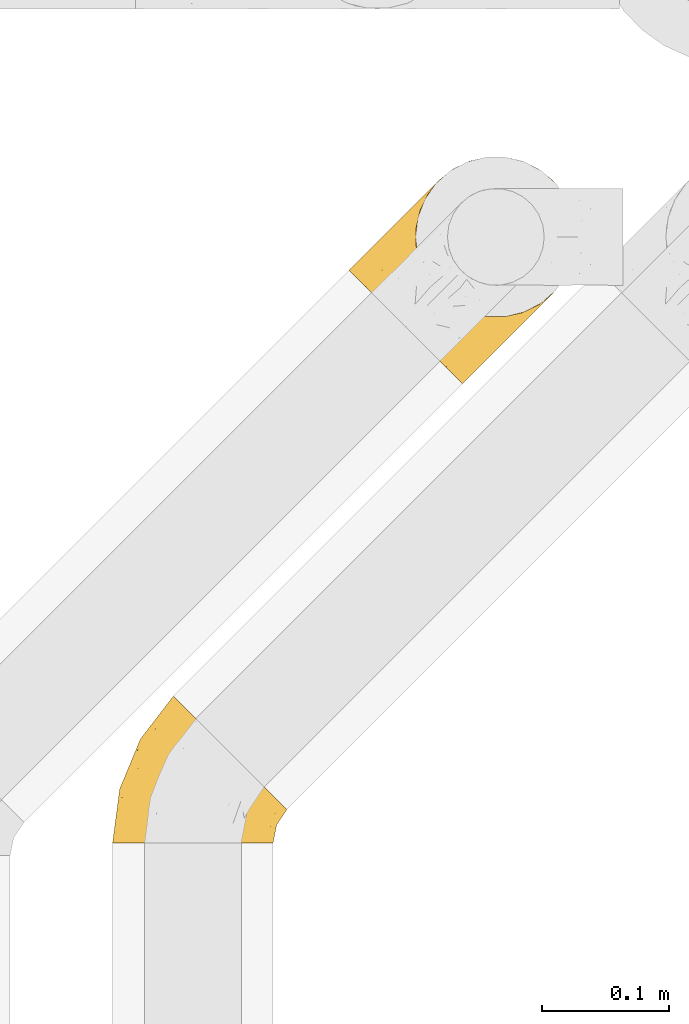
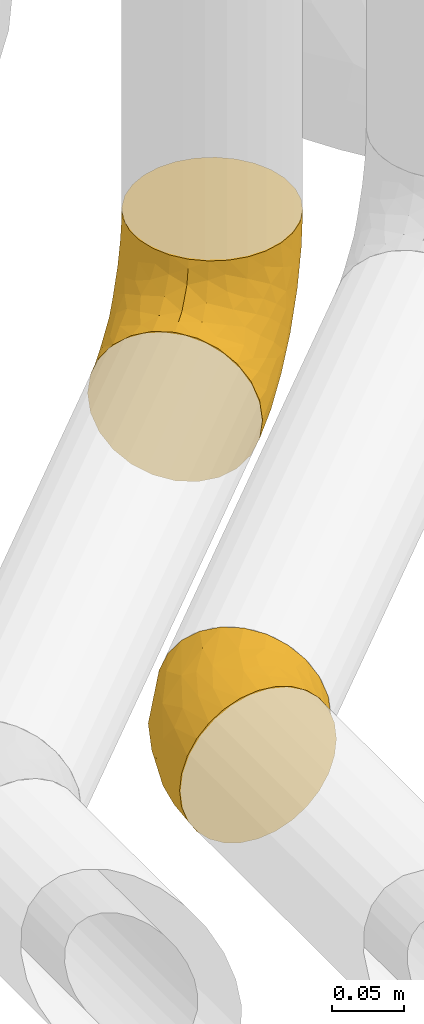
# One storey, part 35 of 93: 2 coverings.
"""IFC2X3 building model written with IfcOpenShell, lengths in millimetres."""

from ifc_helpers import new_model, entity, si_unit, converted_unit, derived_unit, direction, frame, origin, place, context, subcontext, project, spatial, faceted_brep, element, save


model = new_model("IFC2X3")

# Units and contexts
model_context = context("Model", 3, precision=0.01, world=origin(), true_north=direction((6.12303176911189e-17, 1.0)))
body_context = subcontext(model_context, "Body", "Model", "MODEL_VIEW")
ifc_project = project(units=[si_unit("LENGTHUNIT", "METRE", prefix="MILLI"), si_unit("AREAUNIT", "SQUARE_METRE"), si_unit("VOLUMEUNIT", "CUBIC_METRE"), converted_unit("PLANEANGLEUNIT", "DEGREE", entity("IfcRatioMeasure", 0.0174532925199433), si_unit("PLANEANGLEUNIT", "RADIAN"), dimensions=[0, 0, 0, 0, 0, 0, 0]), si_unit("MASSUNIT", "GRAM", prefix="KILO"), derived_unit("MASSDENSITYUNIT", [(si_unit("MASSUNIT", "GRAM", prefix="KILO"), 1), (si_unit("LENGTHUNIT", "METRE"), -3)]), derived_unit("MOMENTOFINERTIAUNIT", [(si_unit("LENGTHUNIT", "METRE"), 4)]), si_unit("TIMEUNIT", "SECOND"), si_unit("FREQUENCYUNIT", "HERTZ"), si_unit("THERMODYNAMICTEMPERATUREUNIT", "DEGREE_CELSIUS"), derived_unit("THERMALTRANSMITTANCEUNIT", [(si_unit("MASSUNIT", "GRAM", prefix="KILO"), 1), (si_unit("THERMODYNAMICTEMPERATUREUNIT", "KELVIN"), -1), (si_unit("TIMEUNIT", "SECOND"), -3)]), derived_unit("VOLUMETRICFLOWRATEUNIT", [(si_unit("LENGTHUNIT", "METRE"), 3), (si_unit("TIMEUNIT", "SECOND"), -1)]), derived_unit("MASSFLOWRATEUNIT", [(si_unit("MASSUNIT", "GRAM", prefix="KILO"), 1), (si_unit("TIMEUNIT", "SECOND"), -1)]), derived_unit("ROTATIONALFREQUENCYUNIT", [(si_unit("TIMEUNIT", "SECOND"), -1)]), si_unit("ELECTRICCURRENTUNIT", "AMPERE"), si_unit("ELECTRICVOLTAGEUNIT", "VOLT"), si_unit("POWERUNIT", "WATT"), si_unit("FORCEUNIT", "NEWTON", prefix="KILO"), si_unit("ILLUMINANCEUNIT", "LUX"), si_unit("LUMINOUSFLUXUNIT", "LUMEN"), si_unit("LUMINOUSINTENSITYUNIT", "CANDELA"), derived_unit("USERDEFINED", [(si_unit("MASSUNIT", "GRAM", prefix="KILO"), -1), (si_unit("LENGTHUNIT", "METRE"), -2), (si_unit("TIMEUNIT", "SECOND"), 3), (si_unit("LUMINOUSFLUXUNIT", "LUMEN"), 1)]), derived_unit("LINEARVELOCITYUNIT", [(si_unit("LENGTHUNIT", "METRE"), 1), (si_unit("TIMEUNIT", "SECOND"), -1)]), si_unit("PRESSUREUNIT", "PASCAL"), derived_unit("USERDEFINED", [(si_unit("LENGTHUNIT", "METRE"), -2), (si_unit("MASSUNIT", "GRAM", prefix="KILO"), 1), (si_unit("TIMEUNIT", "SECOND"), -2)]), derived_unit("LINEARFORCEUNIT", [(si_unit("MASSUNIT", "GRAM", prefix="KILO"), 1), (si_unit("LENGTHUNIT", "METRE"), 1), (si_unit("TIMEUNIT", "SECOND"), -2), (si_unit("LENGTHUNIT", "METRE"), -1)]), derived_unit("PLANARFORCEUNIT", [(si_unit("MASSUNIT", "GRAM", prefix="KILO"), 1), (si_unit("LENGTHUNIT", "METRE"), 1), (si_unit("TIMEUNIT", "SECOND"), -2), (si_unit("LENGTHUNIT", "METRE"), -2)])], contexts=[model_context])

# Site, building, storey
site_placement = place(None, origin())
site = spatial("IfcSite", under=ifc_project, at=site_placement, CompositionType="ELEMENT")
building_placement = place(site_placement, origin())
building = spatial("IfcBuilding", under=site, at=building_placement, CompositionType="ELEMENT")
storey_placement = place(building_placement, frame((0.0, 0.0, -4200.0)))
storey = spatial("IfcBuildingStorey", under=building, at=storey_placement, CompositionType="ELEMENT", Elevation=-4200.0)

# Coverings
covering_1_placement = place(storey_placement, frame((24795.46, 11953.15, 2935.4)))
element("IfcCovering", 1, at=covering_1_placement, inside=storey, Name=":ADSK_", ObjectType=":ADSK_", PredefinedType="INSULATION", context=body_context, shape_type="Brep", body=[
    faceted_brep([(170.2, 83.34, 164.6), (176.32, 96.04, 164.6), (179.46, 109.8, 164.6), (179.46, 123.9, 164.6), (176.32, 137.66, 164.6), (170.2, 150.37, 164.6), (161.4, 161.4, 164.6), (150.37, 170.2, 164.6), (137.66, 176.32, 164.6), (123.91, 179.46, 164.6), (109.8, 179.46, 164.6), (96.05, 176.32, 164.6), (83.34, 170.2, 164.6), (72.31, 161.4, 164.6), (63.51, 150.37, 164.6), (57.39, 137.66, 164.6), (54.25, 123.91, 164.6), (54.25, 109.8, 164.6), (57.39, 96.05, 164.6), (63.51, 83.34, 164.6), (72.31, 72.31, 164.6), (83.34, 63.51, 164.6), (96.04, 57.39, 164.6), (109.8, 54.25, 164.6), (123.9, 54.25, 164.6), (137.66, 57.39, 164.6), (150.37, 63.51, 164.6), (161.4, 72.31, 164.6), (7.56, 84.72, 96.1), (3.11, 89.17, 80.9), (2.64, 89.65, 75.83), (1.6, 90.69, 64.6), (3.11, 89.17, 48.29), (7.56, 84.72, 33.1), (14.64, 77.64, 20.05), (23.87, 68.42, 10.04), (34.61, 57.67, 3.74), (46.14, 46.14, 1.6), (57.67, 34.61, 3.74), (68.42, 23.87, 10.04), (77.64, 14.64, 20.05), (84.72, 7.56, 33.1), (89.17, 3.11, 48.29), (90.69, 1.6, 64.6), (89.65, 2.64, 75.83), (89.17, 3.11, 80.9), (84.72, 7.56, 96.1), (77.64, 14.64, 109.14), (68.42, 23.87, 119.15), (57.67, 34.61, 125.45), (46.14, 46.14, 127.6), (34.61, 57.67, 125.45), (23.87, 68.42, 119.15), (14.64, 77.64, 109.14), (92.67, 41.05, 16.11), (89.38, 58.08, 10.47), (114.72, 66.35, 25.17), (73.84, 57.85, 5.03), (75.97, 75.97, 7.15), (164.16, 94.73, 89.92), (150.24, 84.82, 63.64), (155.13, 105.66, 69.58), (128.48, 100.83, 37.4), (103.77, 103.77, 23.43), (127.64, 127.64, 49.34), (132.1, 49.93, 57.66), (115.76, 38.13, 41.13), (130.83, 62.77, 43.56), (112.06, 26.69, 51.24), (128.21, 40.61, 67.11), (169.64, 111.23, 101.38), (166.05, 124.65, 96.89), (174.42, 129.91, 127.01), (109.63, 77.65, 20.7), (95.36, 79.57, 13.5), (107.56, 40.52, 28.72), (157.47, 157.47, 122.41), (169.3, 142.46, 125.37), (148.08, 125.06, 67.01), (158.77, 139.5, 94.82), (153.98, 77.33, 76.34), (166.46, 78.84, 138.01), (172.41, 90.38, 133.22), (132.25, 43.16, 83.69), (122.4, 33.3, 76.59), (112.54, 23.45, 69.49), (146.96, 60.49, 83.16), (177.46, 117.32, 133.67), (173.91, 102.46, 119.86), (135.86, 81.91, 43.48), (147.9, 58.8, 105.82), (140.08, 50.98, 94.76), (159.87, 70.78, 150.96), (157.94, 68.85, 133.69), (158.88, 71.28, 110.48), (152.92, 63.82, 119.76), (162.84, 80.67, 101.13), (145.96, 145.96, 83.1), (100.33, 11.24, 66.76), (75.99, 54.76, 136.91), (92.06, 52.75, 142.02), (81.36, 61.52, 150.15), (100.35, 13.29, 79.29), (107.79, 26.26, 96.09), (120.38, 32.9, 87.81), (119.61, 35.82, 99.92), (108.27, 21.64, 83.57), (92.44, 45.49, 131.18), (109.09, 42.06, 123.5), (104.37, 47.78, 135.55), (121.9, 53.26, 152.5), (107.87, 52.21, 147.78), (125.77, 51.13, 137.69), (129.48, 44.31, 106.96), (120.16, 42.34, 116.2), (83.38, 39.36, 124.83), (72.12, 33.6, 122.46), (91.0, 27.71, 112.17), (96.5, 17.02, 94.66), (67.98, 45.96, 128.78), (52.68, 52.68, 130.07), (139.06, 56.71, 144.19), (149.41, 61.85, 137.7), (150.1, 63.05, 150.62), (68.8, 68.8, 146.1), (128.78, 47.98, 121.85), (138.08, 51.11, 112.08), (140.29, 54.54, 124.43), (71.05, 71.05, 157.98), (107.6, 34.23, 110.72), (97.13, 36.92, 119.91), (117.73, 47.07, 130.41), (92.73, 57.22, 153.66), (64.01, 64.01, 139.32), (59.22, 59.22, 132.55), (95.09, 22.22, 103.35), (27.71, 91.0, 112.17), (42.34, 120.17, 116.21), (34.23, 107.62, 110.7), (42.06, 109.09, 123.5), (45.96, 67.97, 128.77), (11.24, 100.33, 66.76), (61.52, 81.36, 150.15), (54.76, 76.0, 136.91), (51.13, 125.77, 137.69), (54.55, 140.3, 124.43), (47.98, 128.79, 121.85), (43.16, 132.25, 83.69), (33.3, 122.4, 76.59), (32.89, 120.37, 87.81), (47.07, 117.73, 130.41), (21.64, 108.27, 83.57), (26.26, 107.79, 96.09), (22.22, 95.09, 103.35), (33.6, 72.12, 122.46), (17.02, 96.5, 94.66), (13.29, 100.35, 79.29), (47.78, 104.37, 135.54), (45.49, 92.44, 131.17), (52.75, 92.06, 142.02), (57.22, 92.73, 153.66), (36.91, 97.13, 119.89), (70.78, 159.87, 150.96), (52.21, 107.88, 147.78), (51.11, 138.09, 112.07), (44.31, 129.47, 106.97), (56.71, 139.07, 144.19), (53.26, 121.9, 152.5), (39.36, 83.38, 124.83), (68.85, 157.94, 133.69), (63.05, 150.11, 150.62), (61.86, 149.41, 137.71), (50.98, 140.08, 94.76), (35.82, 119.62, 99.9), (63.82, 152.92, 119.76), (58.8, 147.9, 105.82), (23.45, 112.54, 69.49), (66.35, 114.72, 25.17), (41.05, 92.67, 16.11), (40.52, 107.56, 28.72), (38.13, 115.76, 41.13), (58.08, 89.38, 10.47), (77.95, 93.76, 12.64), (57.83, 73.77, 5.01), (40.61, 128.21, 67.11), (78.84, 166.46, 138.01), (90.39, 172.42, 133.22), (80.67, 162.84, 101.13), (84.82, 150.24, 63.64), (94.74, 164.16, 89.92), (105.66, 155.12, 69.57), (71.28, 158.88, 110.48), (60.49, 146.96, 83.16), (26.69, 112.06, 51.24), (79.75, 110.57, 21.38), (111.24, 169.64, 101.38), (117.33, 177.46, 133.67), (124.66, 166.05, 96.89), (131.19, 175.82, 135.87), (102.47, 173.91, 119.86), (62.77, 130.83, 43.56), (125.06, 148.08, 67.01), (100.83, 128.48, 37.4), (77.34, 153.99, 76.35), (49.93, 132.1, 57.66), (81.91, 135.86, 43.48), (142.47, 169.3, 125.37), (137.22, 160.06, 94.76), (94.75, 110.98, 23.91)], [[[0, 1, 2, 3, 4, 5, 6, 7, 8, 9, 10, 11, 12, 13, 14, 15, 16, 17, 18, 19, 20, 21, 22, 23, 24, 25, 26, 27]], [[28, 29, 30, 31, 32, 33, 34, 35, 36, 37, 38, 39, 40, 41, 42, 43, 44, 45, 46, 47, 48, 49, 50, 51, 52, 53]], [[54, 55, 56]], [[57, 37, 58]], [[59, 60, 61]], [[62, 63, 64]], [[65, 66, 67]], [[68, 65, 69]], [[70, 71, 72]], [[55, 73, 56]], [[39, 38, 55]], [[55, 74, 73]], [[75, 40, 54]], [[40, 39, 54]], [[76, 5, 77]], [[71, 78, 79]], [[41, 75, 66]], [[42, 68, 43]], [[59, 80, 60]], [[0, 81, 82]], [[69, 83, 84, 85]], [[69, 86, 83]], [[82, 1, 0]], [[2, 87, 3]], [[4, 3, 72]], [[40, 75, 41]], [[5, 4, 77]], [[2, 1, 88]], [[72, 3, 87]], [[5, 76, 6]], [[70, 87, 88]], [[68, 66, 65]], [[87, 2, 88]], [[56, 89, 67]], [[78, 62, 64]], [[86, 90, 91, 83]], [[81, 27, 92, 93]], [[62, 61, 89]], [[94, 93, 95, 90]], [[96, 94, 86]], [[38, 57, 55]], [[78, 61, 62]], [[82, 88, 1]], [[78, 64, 97]], [[57, 74, 55]], [[76, 77, 79]], [[77, 72, 71]], [[80, 86, 65]], [[94, 81, 93]], [[96, 88, 82]], [[79, 78, 97]], [[61, 71, 70]], [[86, 94, 90]], [[81, 96, 82]], [[68, 85, 98, 43]], [[86, 69, 65]], [[68, 69, 85]], [[66, 42, 41]], [[66, 68, 42]], [[67, 66, 75]], [[56, 67, 75]], [[67, 60, 80]], [[59, 70, 88]], [[70, 59, 61]], [[60, 67, 89]], [[78, 71, 61]], [[81, 94, 96]], [[27, 81, 0]], [[88, 96, 59]], [[80, 59, 96]], [[86, 80, 96]], [[67, 80, 65]], [[62, 89, 56]], [[61, 60, 89]], [[55, 54, 39]], [[75, 54, 56]], [[37, 57, 38]], [[74, 57, 58]], [[58, 63, 74]], [[62, 74, 63]], [[74, 62, 73]], [[62, 56, 73]], [[4, 72, 77]], [[70, 72, 87]], [[76, 79, 97]], [[71, 79, 77]], [[99, 100, 101]], [[98, 85, 102]], [[103, 104, 105]], [[106, 102, 85]], [[107, 108, 109]], [[106, 85, 84]], [[110, 111, 112]], [[105, 113, 114]], [[115, 116, 117]], [[47, 46, 118]], [[49, 119, 120]], [[48, 47, 117]], [[121, 122, 123]], [[123, 92, 26]], [[48, 116, 49]], [[124, 99, 101]], [[125, 126, 127]], [[127, 121, 112]], [[25, 24, 121]], [[101, 128, 124]], [[117, 129, 130]], [[26, 25, 123]], [[27, 26, 92]], [[131, 109, 108]], [[127, 95, 122]], [[24, 110, 121]], [[21, 20, 128]], [[131, 108, 114]], [[44, 43, 98, 45]], [[129, 114, 108]], [[23, 110, 24]], [[119, 115, 99]], [[101, 132, 21]], [[111, 23, 22]], [[90, 126, 91]], [[99, 124, 133, 134]], [[132, 111, 22]], [[128, 101, 21]], [[135, 47, 118]], [[101, 100, 132]], [[119, 99, 134]], [[107, 99, 115]], [[125, 114, 113]], [[93, 123, 122]], [[112, 125, 127]], [[129, 105, 114]], [[127, 90, 95]], [[120, 50, 49]], [[116, 119, 49]], [[111, 110, 23]], [[121, 110, 112]], [[111, 132, 100]], [[21, 132, 22]], [[125, 112, 131]], [[126, 125, 113]], [[112, 111, 131]], [[109, 111, 100]], [[111, 109, 131]], [[107, 109, 100]], [[99, 107, 100]], [[107, 115, 130]], [[126, 113, 91]], [[90, 127, 126]], [[131, 114, 125]], [[130, 129, 108]], [[135, 129, 117]], [[129, 103, 105]], [[107, 130, 108]], [[117, 130, 115]], [[121, 123, 25]], [[92, 123, 93]], [[127, 122, 121]], [[95, 93, 122]], [[117, 116, 48]], [[119, 116, 115]], [[84, 104, 106]], [[83, 113, 105]], [[103, 118, 106]], [[105, 104, 83]], [[102, 46, 45]], [[106, 104, 103]], [[83, 104, 84]], [[118, 103, 135]], [[102, 118, 46]], [[129, 135, 103]], [[47, 135, 117]], [[102, 106, 118]], [[98, 102, 45]], [[113, 83, 91]], [[119, 134, 120]], [[53, 52, 136]], [[137, 138, 139]], [[51, 120, 140]], [[141, 31, 30, 29]], [[19, 142, 128]], [[143, 134, 133, 124]], [[144, 145, 146]], [[147, 148, 149]], [[150, 144, 146]], [[151, 152, 149]], [[153, 53, 136]], [[52, 154, 136]], [[28, 155, 156]], [[143, 140, 134]], [[157, 158, 159]], [[124, 142, 143]], [[124, 128, 142]], [[18, 160, 19]], [[138, 161, 139]], [[14, 13, 162]], [[156, 141, 29]], [[159, 160, 163]], [[18, 17, 163]], [[164, 165, 146]], [[51, 154, 52]], [[166, 145, 144]], [[157, 163, 150]], [[166, 144, 167]], [[167, 17, 16]], [[16, 15, 166]], [[136, 168, 161]], [[162, 169, 170]], [[15, 14, 170]], [[167, 163, 17]], [[19, 128, 20]], [[171, 145, 166]], [[160, 159, 142]], [[155, 153, 152]], [[170, 166, 15]], [[142, 159, 143]], [[158, 143, 159]], [[140, 143, 168]], [[154, 140, 168]], [[164, 172, 165]], [[138, 173, 152]], [[150, 146, 137]], [[166, 170, 171]], [[174, 175, 145]], [[166, 167, 16]], [[163, 167, 144]], [[19, 160, 142]], [[163, 160, 18]], [[164, 146, 145]], [[137, 146, 165]], [[157, 150, 139]], [[163, 144, 150]], [[139, 161, 158]], [[163, 157, 159]], [[139, 158, 157]], [[143, 158, 168]], [[145, 175, 164]], [[120, 51, 50]], [[173, 138, 137]], [[150, 137, 139]], [[173, 137, 165]], [[153, 138, 152]], [[136, 161, 138]], [[158, 161, 168]], [[162, 170, 14]], [[170, 169, 171]], [[169, 174, 171]], [[145, 171, 174]], [[140, 154, 51]], [[136, 154, 168]], [[165, 147, 173]], [[173, 149, 152]], [[156, 151, 176]], [[151, 148, 176]], [[155, 152, 151]], [[147, 149, 173]], [[151, 149, 148]], [[156, 155, 151]], [[53, 155, 28]], [[53, 153, 155]], [[138, 153, 136]], [[141, 156, 176]], [[28, 156, 29]], [[172, 164, 175]], [[172, 147, 165]], [[120, 134, 140]], [[177, 178, 179]], [[33, 32, 180]], [[181, 182, 183]], [[184, 176, 148, 147]], [[185, 186, 187]], [[188, 189, 190]], [[191, 192, 175]], [[184, 193, 176]], [[194, 181, 177]], [[193, 180, 32]], [[37, 36, 183]], [[195, 196, 197]], [[9, 8, 198]], [[178, 181, 35]], [[36, 35, 181]], [[33, 179, 34]], [[189, 199, 195]], [[193, 31, 141, 176]], [[35, 34, 178]], [[186, 11, 199]], [[192, 147, 172, 175]], [[179, 180, 200]], [[201, 64, 202]], [[179, 200, 177]], [[13, 12, 185]], [[203, 187, 189]], [[12, 11, 186]], [[184, 192, 204]], [[203, 192, 187]], [[10, 199, 11]], [[177, 200, 205]], [[206, 198, 8]], [[207, 201, 197]], [[63, 208, 64]], [[7, 206, 8]], [[194, 182, 181]], [[7, 6, 76]], [[199, 196, 195]], [[196, 10, 9]], [[197, 196, 198]], [[7, 76, 206]], [[10, 196, 199]], [[207, 76, 97]], [[191, 175, 174, 169]], [[64, 201, 97]], [[63, 58, 182]], [[199, 187, 186]], [[187, 191, 185]], [[177, 205, 202]], [[207, 197, 206]], [[192, 184, 147]], [[193, 184, 204]], [[193, 204, 180]], [[31, 193, 32]], [[204, 203, 200]], [[33, 180, 179]], [[204, 200, 180]], [[200, 188, 205]], [[191, 169, 185]], [[192, 191, 187]], [[190, 195, 197]], [[195, 190, 189]], [[197, 201, 190]], [[202, 190, 201]], [[185, 169, 162, 13]], [[186, 185, 12]], [[203, 189, 188]], [[187, 199, 189]], [[200, 203, 188]], [[192, 203, 204]], [[188, 190, 205]], [[202, 205, 190]], [[179, 178, 34]], [[181, 178, 177]], [[177, 202, 194]], [[182, 208, 63]], [[182, 194, 208]], [[183, 182, 58]], [[37, 183, 58]], [[181, 183, 36]], [[194, 202, 208]], [[64, 208, 202]], [[197, 198, 206]], [[9, 198, 196]], [[76, 207, 206]], [[97, 201, 207]]]),
])
covering_2_placement = place(storey_placement, frame((24609.86, 11592.72, 2935.4)))
element("IfcCovering", 2, at=covering_2_placement, inside=storey, Name=":ADSK_", ObjectType=":ADSK_", PredefinedType="INSULATION", context=body_context, shape_type="Brep", body=[
    faceted_brep([(127.6, 1.6, 64.6), (126.02, 1.6, 78.61), (121.36, 1.6, 91.93), (113.85, 1.6, 103.87), (103.88, 1.6, 113.85), (91.93, 1.6, 121.35), (78.62, 1.6, 126.01), (64.6, 1.6, 127.6), (50.58, 1.6, 126.02), (37.26, 1.6, 121.36), (25.32, 1.6, 113.85), (15.34, 1.6, 103.88), (7.84, 1.6, 91.93), (3.18, 1.6, 78.62), (1.6, 1.6, 64.6), (3.17, 1.6, 50.58), (7.83, 1.6, 37.26), (15.34, 1.6, 25.32), (25.31, 1.6, 15.34), (37.26, 1.6, 7.84), (50.57, 1.6, 3.18), (64.6, 1.6, 1.6), (78.61, 1.6, 3.17), (91.93, 1.6, 7.83), (103.87, 1.6, 15.34), (113.85, 1.6, 25.31), (121.35, 1.6, 37.26), (126.01, 1.6, 50.57), (116.16, 50.03, 10.04), (105.41, 60.78, 3.74), (93.88, 72.31, 1.6), (82.35, 83.84, 3.74), (71.61, 94.58, 10.04), (62.38, 103.81, 20.05), (55.31, 110.89, 33.1), (50.85, 115.34, 48.29), (49.34, 116.85, 64.6), (50.85, 115.34, 80.9), (55.31, 110.89, 96.1), (62.38, 103.81, 109.14), (71.61, 94.58, 119.15), (82.35, 83.84, 125.45), (93.88, 72.31, 127.6), (105.41, 60.78, 125.45), (116.16, 50.03, 119.15), (120.77, 45.42, 114.15), (125.38, 40.81, 109.14), (132.46, 33.73, 96.1), (136.91, 29.28, 80.9), (138.43, 27.76, 64.6), (136.91, 29.28, 48.29), (132.46, 33.73, 33.1), (125.38, 40.81, 20.05), (120.77, 45.42, 15.04), (22.6, 33.82, 108.06), (23.43, 83.1, 64.6), (39.51, 85.62, 102.01), (7.15, 43.78, 64.6), (21.33, 74.5, 81.29), (54.41, 47.23, 124.58), (42.67, 26.33, 122.68), (60.82, 72.24, 122.19), (8.89, 37.3, 84.57), (37.93, 62.02, 112.99), (77.99, 51.6, 127.6), (85.47, 61.34, 127.6), (13.21, 29.09, 97.28), (21.55, 59.83, 96.29), (32.6, 29.32, 117.06), (35.12, 91.1, 90.56), (66.4, 15.3, 127.6), (68.0, 27.48, 127.6), (73.0, 39.54, 127.6), (44.38, 52.36, 119.72), (108.74, 40.86, 119.02), (96.7, 47.06, 124.88), (111.89, 30.85, 113.49), (94.64, 27.4, 122.23), (95.49, 13.62, 120.07), (107.76, 15.33, 111.97), (118.96, 19.92, 101.82), (117.56, 9.76, 99.77), (132.32, 21.41, 75.01), (125.3, 14.35, 87.5), (127.95, 11.58, 75.66), (129.01, 24.77, 90.26), (81.37, 29.18, 126.38), (81.14, 15.88, 125.7), (85.44, 40.48, 126.48), (130.41, 15.75, 64.6), (122.25, 30.66, 104.64), (125.3, 14.35, 41.69), (107.76, 15.33, 17.22), (130.99, 19.96, 51.88), (108.74, 40.86, 10.17), (127.14, 24.41, 36.0), (118.96, 19.92, 27.36), (96.7, 47.06, 4.31), (85.47, 61.34, 1.6), (94.64, 27.4, 6.96), (86.43, 38.13, 3.11), (117.56, 9.76, 29.41), (81.13, 15.88, 3.49), (82.94, 27.28, 3.26), (95.48, 13.62, 9.12), (111.89, 30.85, 15.69), (127.93, 10.6, 54.84), (73.0, 39.54, 1.6), (77.99, 51.6, 1.6), (68.0, 27.48, 1.6), (66.4, 15.3, 1.6), (122.33, 31.09, 24.34), (54.41, 47.23, 4.61), (60.82, 72.24, 7.0), (22.59, 33.82, 21.14), (37.93, 62.01, 16.2), (32.6, 29.32, 12.13), (13.21, 29.09, 31.92), (21.55, 59.83, 32.9), (39.5, 85.61, 27.18), (35.12, 91.1, 38.63), (8.88, 37.3, 44.63), (21.32, 74.49, 47.91), (42.67, 26.33, 6.52), (44.38, 52.36, 9.47)], [[[0, 1, 2, 3, 4, 5, 6, 7, 8, 9, 10, 11, 12, 13, 14, 15, 16, 17, 18, 19, 20, 21, 22, 23, 24, 25, 26, 27]], [[28, 29, 30, 31, 32, 33, 34, 35, 36, 37, 38, 39, 40, 41, 42, 43, 44, 45, 46, 47, 48, 49, 50, 51, 52, 53]], [[54, 11, 10]], [[37, 36, 55]], [[38, 56, 39]], [[55, 57, 58]], [[8, 59, 60]], [[41, 61, 59]], [[57, 13, 62]], [[63, 40, 39]], [[41, 64, 65, 42]], [[64, 41, 59]], [[61, 41, 40]], [[66, 54, 67]], [[56, 63, 39]], [[63, 67, 54]], [[62, 58, 57]], [[62, 67, 58]], [[54, 10, 68]], [[66, 12, 11]], [[66, 62, 12]], [[13, 57, 14]], [[63, 56, 67]], [[69, 56, 38]], [[37, 58, 69]], [[63, 54, 68]], [[68, 10, 9]], [[8, 7, 70, 71]], [[59, 71, 72, 64]], [[59, 8, 71]], [[62, 66, 67]], [[54, 66, 11]], [[73, 59, 61]], [[37, 55, 58]], [[60, 68, 9]], [[62, 13, 12]], [[37, 69, 38]], [[67, 56, 69]], [[67, 69, 58]], [[8, 60, 9]], [[73, 60, 59]], [[40, 63, 61]], [[73, 61, 63]], [[63, 68, 73]], [[60, 73, 68]], [[46, 45, 44, 74]], [[64, 75, 65]], [[76, 74, 77]], [[65, 75, 43]], [[44, 75, 74]], [[78, 79, 77]], [[80, 76, 79]], [[81, 3, 2]], [[82, 49, 48]], [[83, 84, 82]], [[77, 79, 76]], [[75, 44, 43]], [[83, 85, 80]], [[47, 85, 48]], [[86, 87, 77]], [[79, 78, 4]], [[5, 4, 78]], [[87, 6, 5]], [[78, 87, 5]], [[87, 70, 6]], [[72, 86, 88]], [[43, 42, 65]], [[81, 79, 3]], [[89, 84, 0]], [[84, 83, 1]], [[1, 83, 2]], [[3, 79, 4]], [[76, 90, 46]], [[83, 80, 81]], [[80, 90, 76]], [[70, 87, 71]], [[88, 64, 72]], [[70, 7, 6]], [[87, 78, 77]], [[87, 86, 71]], [[83, 81, 2]], [[79, 81, 80]], [[0, 84, 1]], [[82, 84, 89]], [[49, 82, 89]], [[82, 48, 85]], [[85, 47, 90]], [[82, 85, 83]], [[85, 90, 80]], [[46, 90, 47]], [[74, 76, 46]], [[77, 74, 75]], [[88, 77, 75]], [[71, 86, 72]], [[77, 88, 86]], [[64, 88, 75]], [[27, 26, 91]], [[25, 24, 92]], [[89, 93, 49]], [[28, 53, 52, 94]], [[95, 91, 96]], [[95, 50, 93]], [[97, 98, 29]], [[97, 99, 100]], [[92, 101, 25]], [[102, 103, 104]], [[92, 105, 96]], [[97, 29, 28]], [[104, 92, 24]], [[92, 99, 105]], [[106, 91, 93]], [[99, 103, 100]], [[26, 101, 91]], [[100, 103, 107]], [[92, 96, 101]], [[52, 105, 94]], [[101, 26, 25]], [[23, 22, 102]], [[104, 24, 23]], [[91, 95, 93]], [[97, 100, 108]], [[109, 102, 110]], [[102, 22, 110]], [[99, 94, 105]], [[52, 51, 111]], [[92, 104, 99]], [[106, 0, 27]], [[22, 21, 110]], [[102, 104, 23]], [[98, 97, 108]], [[98, 30, 29]], [[91, 101, 96]], [[111, 95, 96]], [[50, 95, 51]], [[49, 93, 50]], [[106, 93, 89]], [[0, 106, 89]], [[91, 106, 27]], [[95, 111, 51]], [[96, 105, 111]], [[105, 52, 111]], [[99, 97, 94]], [[97, 28, 94]], [[99, 104, 103]], [[108, 100, 107]], [[102, 109, 103]], [[107, 103, 109]], [[31, 112, 113]], [[114, 115, 116]], [[31, 30, 98, 108]], [[114, 116, 18]], [[114, 117, 118]], [[119, 115, 118]], [[36, 35, 55]], [[118, 120, 119]], [[121, 122, 118]], [[115, 119, 33]], [[32, 115, 33]], [[34, 119, 120]], [[120, 118, 122]], [[19, 123, 20]], [[112, 108, 107, 109]], [[124, 115, 113]], [[20, 109, 110, 21]], [[33, 119, 34]], [[114, 18, 17]], [[55, 35, 122]], [[118, 115, 114]], [[112, 31, 108]], [[120, 35, 34]], [[116, 19, 18]], [[122, 121, 57]], [[117, 17, 16]], [[15, 14, 57]], [[15, 57, 121]], [[123, 19, 116]], [[117, 121, 118]], [[122, 57, 55]], [[15, 121, 16]], [[117, 114, 17]], [[20, 112, 109]], [[121, 117, 16]], [[31, 113, 32]], [[35, 120, 122]], [[124, 123, 116]], [[20, 123, 112]], [[124, 113, 112]], [[115, 32, 113]], [[123, 124, 112]], [[116, 115, 124]]]),
])

save(model, "model.ifc")
